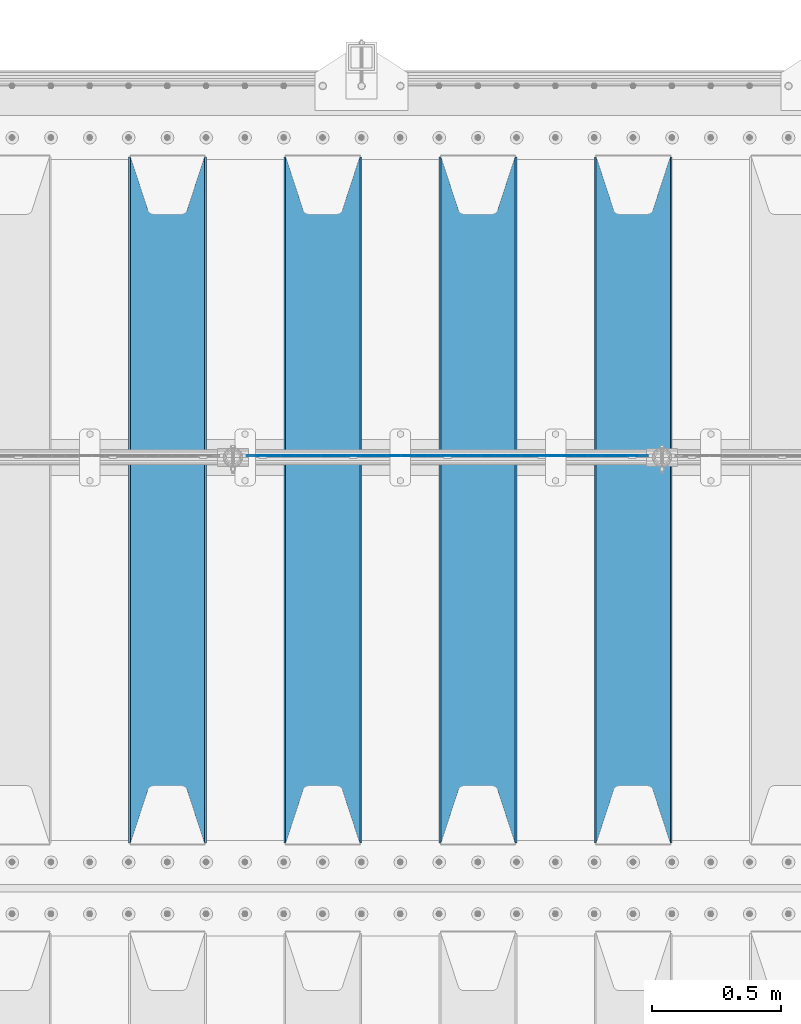
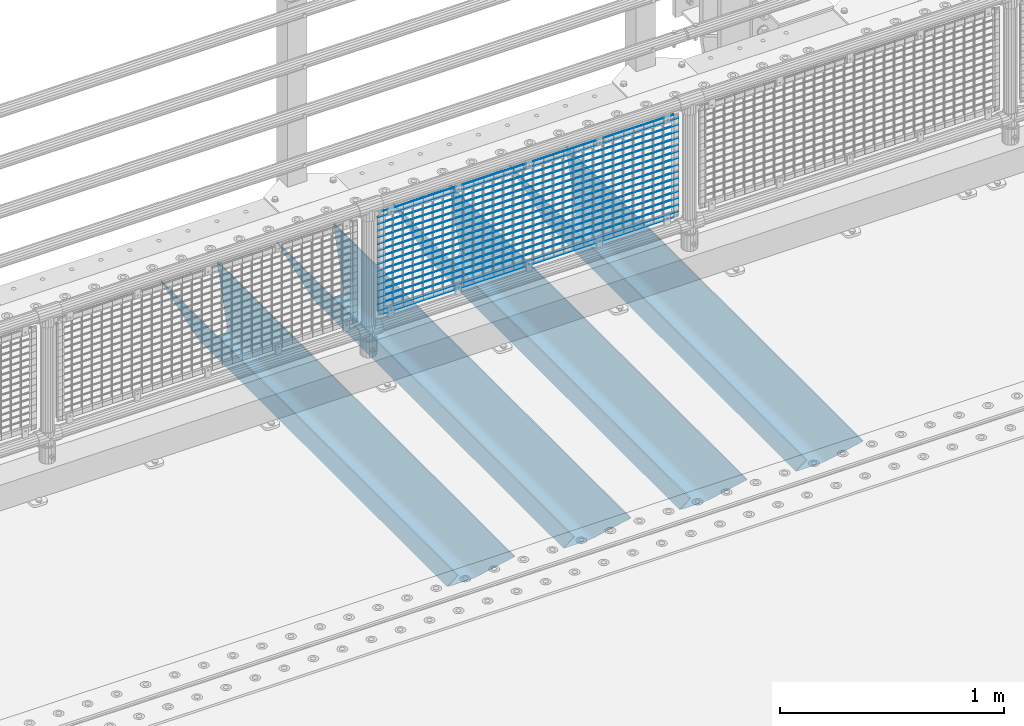
# One storey, part 121 of 240: 21 beams.
"""IFC2X3 building model written with IfcOpenShell, lengths in millimetres."""

from ifc_helpers import new_model, si_unit, frame, origin_with_axes, place, context, subcontext, project, spatial, faceted_brep, material, type_object, element, save


model = new_model("IFC2X3")

# Units and contexts
model_context = context("Model", 3, precision=1e-05, world=origin_with_axes())
body_context = subcontext(model_context, "Body", "Model", "MODEL_VIEW")
ifc_project = project(units=[si_unit("LENGTHUNIT", "METRE", prefix="MILLI"), si_unit("AREAUNIT", "SQUARE_METRE"), si_unit("VOLUMEUNIT", "CUBIC_METRE"), si_unit("MASSUNIT", "GRAM", prefix="KILO"), si_unit("TIMEUNIT", "SECOND"), si_unit("PLANEANGLEUNIT", "RADIAN"), si_unit("SOLIDANGLEUNIT", "STERADIAN"), si_unit("THERMODYNAMICTEMPERATUREUNIT", "DEGREE_CELSIUS"), si_unit("LUMINOUSINTENSITYUNIT", "LUMEN")], contexts=[model_context])

# Site, building, storey
site_placement = place(None, origin_with_axes())
site = spatial("IfcSite", under=ifc_project, at=site_placement, CompositionType="ELEMENT")
building_placement = place(site_placement, origin_with_axes())
building = spatial("IfcBuilding", under=site, at=building_placement, Name="Standard", CompositionType="ELEMENT")
storey_placement = place(building_placement, origin_with_axes())
storey = spatial("IfcBuildingStorey", under=building, at=storey_placement, Name="Undefined", CompositionType="ELEMENT", Elevation=0.0)

# Beams
ifc_material_1 = material(Name="STEEL/S355N")
beam_type_1 = type_object("IfcBeamType", PredefinedType="NOTDEFINED")
beam_1_placement = place(storey_placement, frame((51250.0, 33175.0, -115.0), z_axis=(0.0, 0.0, 1.0), x_axis=(0.0, 1.0, 0.0)))
element("IfcBeam", 1, at=beam_1_placement, inside=storey, type_object=beam_type_1, material=ifc_material_1, context=body_context, shape_type="Brep", body=[
    faceted_brep([(0.0, 150.0, 115.0), (0.0, 143.690000000002, 115.0), (2650.00000000297, 143.690000000002, 115.0), (2650.00000000297, 150.0, 115.0), (2650.00000000297, 142.059565218406, 110.000000003094), (2650.00000000297, 148.369565218403, 110.000000003094), (2441.90079219209, -80.1103600731149, -98.0992078077845), (2437.7588105432, -77.5672621345584, -102.241189456673), (2434.06523489747, -74.4080125315522, -105.934765102404), (2430.9108609509, -70.7102721255724, -109.089139048974), (2428.37322971128, -66.5649389910031, -111.626770288588), (2426.51472138055, -62.0739139532889, -113.485278619323), (2425.38102192092, -57.3475956567636, -114.618978078955), (2424.99999999987, -52.5021667386536, -115.0), (2424.99999999987, 52.5021667386536, -115.0), (2425.38102192092, 57.3475956567636, -114.618978078955), (2426.51472138055, 62.0739139532889, -113.485278619323), (2428.37322971128, 66.5649389910031, -111.626770288588), (2430.9108609509, 70.7102721255724, -109.089139048974), (2434.06523489747, 74.4080125315522, -105.934765102404), (2437.7588105432, 77.5672621345584, -102.241189456673), (2441.90079219209, 80.1103600731149, -98.0992078077846), (2446.38936140512, 81.9747917625791, -93.6106385947584), (2448.2494850041, 76.2713538057287, -91.7505149957729), (2444.62967112263, 74.76777986261, -95.3703288772456), (2441.28936334127, 72.7168944282894, -98.710636658607), (2438.31067330439, 70.1691124903809, -101.689326695487), (2435.76682334748, 67.1870637758839, -104.233176652398), (2433.72034654134, 63.8440531834931, -106.279653458539), (2432.22154950042, 60.2222587982324, -107.778450499454), (2431.30727574265, 56.4107117849126, -108.692724257221), (2430.99999999987, 52.5031078186876, -109.0), (2430.99999999987, -52.5031078186876, -109.0), (2431.30727574265, -56.4107117849126, -108.692724257221), (2432.22154950042, -60.2222587982324, -107.778450499454), (2433.72034654134, -63.8440531834931, -106.279653458539), (2435.76682334748, -67.1870637758839, -104.233176652398), (2438.31067330439, -70.1691124903809, -101.689326695487), (2441.28936334127, -72.7168944282894, -98.7106366586071), (2444.62967112263, -74.76777986261, -95.3703288772457), (2448.2494850041, -76.2713538057287, -91.7505149957729), (2650.00000000297, -142.059565218406, 110.000000003094), (2650.00000000297, -148.369565218403, 110.000000003094), (2446.38936140512, -81.9747917625791, -93.6106385947584), (2650.00000000297, -143.690000000002, 115.0), (2650.00000000297, -150.0, 115.0), (0.0, -143.690000000002, 115.0), (0.0, -150.0, 115.0), (0.0, -148.369565218258, 110.000000002667), (203.610638597427, -81.9747917625791, -93.6106385947584), (208.09920781045, -80.1103600731149, -98.0992078077845), (212.241189459342, -77.5672621345584, -102.241189456673), (215.93476510507, -74.4080125315522, -105.934765102404), (219.089139051641, -70.7102721255724, -109.089139048974), (221.626770291256, -66.5649389910031, -111.626770288588), (223.485278621989, -62.0739139532889, -113.485278619323), (224.618978081624, -57.3475956567636, -114.618978078955), (225.000000002663, -52.5021667386536, -115.0), (225.000000002663, 52.5021667386536, -115.0), (224.618978081624, 57.3475956567636, -114.618978078955), (223.485278621989, 62.0739139532889, -113.485278619323), (221.626770291256, 66.5649389910031, -111.626770288588), (219.089139051641, 70.7102721255724, -109.089139048974), (215.93476510507, 74.4080125315522, -105.934765102404), (212.241189459342, 77.5672621345584, -102.241189456673), (208.09920781045, 80.1103600731149, -98.0992078077846), (203.610638597427, 81.9747917625791, -93.6106385947584), (0.0, 148.369565218258, 110.000000002667), (0.0, 142.05956521826, 110.000000002667), (201.750514998439, 76.2713538057287, -91.7505149957729), (205.370328879908, 74.76777986261, -95.3703288772456), (208.710636661275, 72.7168944282894, -98.710636658607), (211.689326698153, 70.1691124903809, -101.689326695487), (214.233176655063, 67.1870637758839, -104.233176652398), (216.279653461206, 63.8440531834931, -106.279653458539), (217.778450502123, 60.2222587982324, -107.778450499454), (218.692724259887, 56.4107117849126, -108.692724257221), (219.000000002667, 52.5031078186876, -109.0), (219.000000002667, -52.5031078186876, -109.0), (218.692724259887, -56.4107117849126, -108.692724257221), (217.778450502123, -60.2222587982324, -107.778450499454), (216.279653461206, -63.8440531834931, -106.279653458539), (214.233176655063, -67.1870637758839, -104.233176652398), (211.689326698153, -70.1691124903809, -101.689326695487), (208.710636661275, -72.7168944282894, -98.7106366586071), (205.370328879915, -74.76777986261, -95.3703288772457), (201.750514998439, -76.2713538057287, -91.7505149957729), (0.0, -142.05956521826, 110.000000002667)], [[[0, 1, 2, 3]], [[3, 2, 4, 5]], [[6, 7, 8, 9, 10, 11, 12, 13, 14, 15, 16, 17, 18, 19, 20, 21, 22, 5, 4, 23, 24, 25, 26, 27, 28, 29, 30, 31, 32, 33, 34, 35, 36, 37, 38, 39, 40, 41, 42, 43]], [[44, 45, 42, 41]], [[46, 47, 45, 44]], [[43, 42, 45, 47, 48, 49]], [[6, 43, 49, 50]], [[7, 6, 50, 51]], [[8, 7, 51, 52]], [[9, 8, 52, 53]], [[10, 9, 53, 54]], [[11, 10, 54, 55]], [[12, 11, 55, 56]], [[13, 12, 56, 57]], [[14, 13, 57, 58]], [[15, 14, 58, 59]], [[16, 15, 59, 60]], [[17, 16, 60, 61]], [[18, 17, 61, 62]], [[19, 18, 62, 63]], [[20, 19, 63, 64]], [[21, 20, 64, 65]], [[22, 21, 65, 66]], [[0, 3, 5, 22, 66, 67]], [[1, 0, 67, 68]], [[23, 4, 2, 1, 68, 69]], [[24, 23, 69, 70]], [[25, 24, 70, 71]], [[26, 25, 71, 72]], [[27, 26, 72, 73]], [[28, 27, 73, 74]], [[29, 28, 74, 75]], [[30, 29, 75, 76]], [[31, 30, 76, 77]], [[32, 31, 77, 78]], [[33, 32, 78, 79]], [[34, 33, 79, 80]], [[35, 34, 80, 81]], [[36, 35, 81, 82]], [[37, 36, 82, 83]], [[38, 37, 83, 84]], [[39, 38, 84, 85]], [[40, 39, 85, 86]], [[46, 44, 41, 40, 86, 87]], [[47, 46, 87, 48]], [[86, 85, 84, 83, 82, 81, 80, 79, 78, 77, 76, 75, 74, 73, 72, 71, 70, 69, 68, 67, 66, 65, 64, 63, 62, 61, 60, 59, 58, 57, 56, 55, 54, 53, 52, 51, 50, 49, 48, 87]]]),
])
beam_2_placement = place(storey_placement, frame((50650.0, 33175.0, -115.0), z_axis=(0.0, 0.0, 1.0), x_axis=(0.0, 1.0, 0.0)))
element("IfcBeam", 2, at=beam_2_placement, inside=storey, type_object=beam_type_1, material=ifc_material_1, context=body_context, shape_type="Brep", body=[
    faceted_brep([(0.0, 150.0, 115.0), (0.0, 143.690000000002, 115.0), (2650.00000000297, 143.690000000002, 115.0), (2650.00000000297, 150.0, 115.0), (2650.00000000297, 142.059565218406, 110.000000003094), (2650.00000000297, 148.369565218403, 110.000000003094), (2441.90079219209, -80.1103600731149, -98.0992078077845), (2437.7588105432, -77.5672621345584, -102.241189456673), (2434.06523489747, -74.4080125315522, -105.934765102404), (2430.9108609509, -70.7102721255724, -109.089139048974), (2428.37322971128, -66.5649389910031, -111.626770288588), (2426.51472138055, -62.0739139532889, -113.485278619323), (2425.38102192092, -57.3475956567636, -114.618978078955), (2424.99999999987, -52.5021667386536, -115.0), (2424.99999999987, 52.5021667386536, -115.0), (2425.38102192092, 57.3475956567636, -114.618978078955), (2426.51472138055, 62.0739139532889, -113.485278619323), (2428.37322971128, 66.5649389910031, -111.626770288588), (2430.9108609509, 70.7102721255724, -109.089139048974), (2434.06523489747, 74.4080125315522, -105.934765102404), (2437.7588105432, 77.5672621345584, -102.241189456673), (2441.90079219209, 80.1103600731149, -98.0992078077846), (2446.38936140512, 81.9747917625791, -93.6106385947584), (2448.2494850041, 76.2713538057287, -91.7505149957729), (2444.62967112263, 74.76777986261, -95.3703288772456), (2441.28936334127, 72.7168944282894, -98.710636658607), (2438.31067330439, 70.1691124903809, -101.689326695487), (2435.76682334748, 67.1870637758839, -104.233176652398), (2433.72034654134, 63.8440531834931, -106.279653458539), (2432.22154950042, 60.2222587982324, -107.778450499454), (2431.30727574265, 56.4107117849126, -108.692724257221), (2430.99999999987, 52.5031078186876, -109.0), (2430.99999999987, -52.5031078186876, -109.0), (2431.30727574265, -56.4107117849126, -108.692724257221), (2432.22154950042, -60.2222587982324, -107.778450499454), (2433.72034654134, -63.8440531834931, -106.279653458539), (2435.76682334748, -67.1870637758839, -104.233176652398), (2438.31067330439, -70.1691124903809, -101.689326695487), (2441.28936334127, -72.7168944282894, -98.7106366586071), (2444.62967112263, -74.76777986261, -95.3703288772457), (2448.2494850041, -76.2713538057287, -91.7505149957729), (2650.00000000297, -142.059565218406, 110.000000003094), (2650.00000000297, -148.369565218403, 110.000000003094), (2446.38936140512, -81.9747917625791, -93.6106385947584), (2650.00000000297, -143.690000000002, 115.0), (2650.00000000297, -150.0, 115.0), (0.0, -143.690000000002, 115.0), (0.0, -150.0, 115.0), (0.0, -148.369565218258, 110.000000002667), (203.610638597427, -81.9747917625791, -93.6106385947584), (208.09920781045, -80.1103600731149, -98.0992078077845), (212.241189459342, -77.5672621345584, -102.241189456673), (215.93476510507, -74.4080125315522, -105.934765102404), (219.089139051641, -70.7102721255724, -109.089139048974), (221.626770291256, -66.5649389910031, -111.626770288588), (223.485278621989, -62.0739139532889, -113.485278619323), (224.618978081624, -57.3475956567636, -114.618978078955), (225.000000002663, -52.5021667386536, -115.0), (225.000000002663, 52.5021667386536, -115.0), (224.618978081624, 57.3475956567636, -114.618978078955), (223.485278621989, 62.0739139532889, -113.485278619323), (221.626770291256, 66.5649389910031, -111.626770288588), (219.089139051641, 70.7102721255724, -109.089139048974), (215.93476510507, 74.4080125315522, -105.934765102404), (212.241189459342, 77.5672621345584, -102.241189456673), (208.09920781045, 80.1103600731149, -98.0992078077846), (203.610638597427, 81.9747917625791, -93.6106385947584), (0.0, 148.369565218258, 110.000000002667), (0.0, 142.05956521826, 110.000000002667), (201.750514998439, 76.2713538057287, -91.7505149957729), (205.370328879908, 74.76777986261, -95.3703288772456), (208.710636661275, 72.7168944282894, -98.710636658607), (211.689326698153, 70.1691124903809, -101.689326695487), (214.233176655063, 67.1870637758839, -104.233176652398), (216.279653461206, 63.8440531834931, -106.279653458539), (217.778450502123, 60.2222587982324, -107.778450499454), (218.692724259887, 56.4107117849126, -108.692724257221), (219.000000002667, 52.5031078186876, -109.0), (219.000000002667, -52.5031078186876, -109.0), (218.692724259887, -56.4107117849126, -108.692724257221), (217.778450502123, -60.2222587982324, -107.778450499454), (216.279653461206, -63.8440531834931, -106.279653458539), (214.233176655063, -67.1870637758839, -104.233176652398), (211.689326698153, -70.1691124903809, -101.689326695487), (208.710636661275, -72.7168944282894, -98.7106366586071), (205.370328879915, -74.76777986261, -95.3703288772457), (201.750514998439, -76.2713538057287, -91.7505149957729), (0.0, -142.05956521826, 110.000000002667)], [[[0, 1, 2, 3]], [[3, 2, 4, 5]], [[6, 7, 8, 9, 10, 11, 12, 13, 14, 15, 16, 17, 18, 19, 20, 21, 22, 5, 4, 23, 24, 25, 26, 27, 28, 29, 30, 31, 32, 33, 34, 35, 36, 37, 38, 39, 40, 41, 42, 43]], [[44, 45, 42, 41]], [[46, 47, 45, 44]], [[43, 42, 45, 47, 48, 49]], [[6, 43, 49, 50]], [[7, 6, 50, 51]], [[8, 7, 51, 52]], [[9, 8, 52, 53]], [[10, 9, 53, 54]], [[11, 10, 54, 55]], [[12, 11, 55, 56]], [[13, 12, 56, 57]], [[14, 13, 57, 58]], [[15, 14, 58, 59]], [[16, 15, 59, 60]], [[17, 16, 60, 61]], [[18, 17, 61, 62]], [[19, 18, 62, 63]], [[20, 19, 63, 64]], [[21, 20, 64, 65]], [[22, 21, 65, 66]], [[0, 3, 5, 22, 66, 67]], [[1, 0, 67, 68]], [[23, 4, 2, 1, 68, 69]], [[24, 23, 69, 70]], [[25, 24, 70, 71]], [[26, 25, 71, 72]], [[27, 26, 72, 73]], [[28, 27, 73, 74]], [[29, 28, 74, 75]], [[30, 29, 75, 76]], [[31, 30, 76, 77]], [[32, 31, 77, 78]], [[33, 32, 78, 79]], [[34, 33, 79, 80]], [[35, 34, 80, 81]], [[36, 35, 81, 82]], [[37, 36, 82, 83]], [[38, 37, 83, 84]], [[39, 38, 84, 85]], [[40, 39, 85, 86]], [[46, 44, 41, 40, 86, 87]], [[47, 46, 87, 48]], [[86, 85, 84, 83, 82, 81, 80, 79, 78, 77, 76, 75, 74, 73, 72, 71, 70, 69, 68, 67, 66, 65, 64, 63, 62, 61, 60, 59, 58, 57, 56, 55, 54, 53, 52, 51, 50, 49, 48, 87]]]),
])
beam_3_placement = place(storey_placement, frame((50050.0, 33175.0, -115.0), z_axis=(0.0, 0.0, 1.0), x_axis=(0.0, 1.0, 0.0)))
element("IfcBeam", 3, at=beam_3_placement, inside=storey, type_object=beam_type_1, material=ifc_material_1, context=body_context, shape_type="Brep", body=[
    faceted_brep([(0.0, 150.0, 115.0), (0.0, 143.690000000002, 115.0), (2650.00000000297, 143.690000000002, 115.0), (2650.00000000297, 150.0, 115.0), (2650.00000000297, 142.059565218406, 110.000000003094), (2650.00000000297, 148.369565218403, 110.000000003094), (2441.90079219209, -80.1103600731149, -98.0992078077845), (2437.7588105432, -77.5672621345584, -102.241189456673), (2434.06523489747, -74.4080125315522, -105.934765102404), (2430.9108609509, -70.7102721255724, -109.089139048974), (2428.37322971128, -66.5649389910031, -111.626770288588), (2426.51472138055, -62.0739139532889, -113.485278619323), (2425.38102192092, -57.3475956567636, -114.618978078955), (2424.99999999987, -52.5021667386536, -115.0), (2424.99999999987, 52.5021667386536, -115.0), (2425.38102192092, 57.3475956567636, -114.618978078955), (2426.51472138055, 62.0739139532889, -113.485278619323), (2428.37322971128, 66.5649389910031, -111.626770288588), (2430.9108609509, 70.7102721255724, -109.089139048974), (2434.06523489747, 74.4080125315522, -105.934765102404), (2437.7588105432, 77.5672621345584, -102.241189456673), (2441.90079219209, 80.1103600731149, -98.0992078077846), (2446.38936140512, 81.9747917625791, -93.6106385947584), (2448.2494850041, 76.2713538057287, -91.7505149957729), (2444.62967112263, 74.76777986261, -95.3703288772456), (2441.28936334127, 72.7168944282894, -98.710636658607), (2438.31067330439, 70.1691124903809, -101.689326695487), (2435.76682334748, 67.1870637758839, -104.233176652398), (2433.72034654134, 63.8440531834931, -106.279653458539), (2432.22154950042, 60.2222587982324, -107.778450499454), (2431.30727574265, 56.4107117849126, -108.692724257221), (2430.99999999987, 52.5031078186876, -109.0), (2430.99999999987, -52.5031078186876, -109.0), (2431.30727574265, -56.4107117849126, -108.692724257221), (2432.22154950042, -60.2222587982324, -107.778450499454), (2433.72034654134, -63.8440531834931, -106.279653458539), (2435.76682334748, -67.1870637758839, -104.233176652398), (2438.31067330439, -70.1691124903809, -101.689326695487), (2441.28936334127, -72.7168944282894, -98.7106366586071), (2444.62967112263, -74.76777986261, -95.3703288772457), (2448.2494850041, -76.2713538057287, -91.7505149957729), (2650.00000000297, -142.059565218406, 110.000000003094), (2650.00000000297, -148.369565218403, 110.000000003094), (2446.38936140512, -81.9747917625791, -93.6106385947584), (2650.00000000297, -143.690000000002, 115.0), (2650.00000000297, -150.0, 115.0), (0.0, -143.690000000002, 115.0), (0.0, -150.0, 115.0), (0.0, -148.369565218258, 110.000000002667), (203.610638597427, -81.9747917625791, -93.6106385947584), (208.09920781045, -80.1103600731149, -98.0992078077845), (212.241189459342, -77.5672621345584, -102.241189456673), (215.93476510507, -74.4080125315522, -105.934765102404), (219.089139051641, -70.7102721255724, -109.089139048974), (221.626770291256, -66.5649389910031, -111.626770288588), (223.485278621989, -62.0739139532889, -113.485278619323), (224.618978081624, -57.3475956567636, -114.618978078955), (225.000000002663, -52.5021667386536, -115.0), (225.000000002663, 52.5021667386536, -115.0), (224.618978081624, 57.3475956567636, -114.618978078955), (223.485278621989, 62.0739139532889, -113.485278619323), (221.626770291256, 66.5649389910031, -111.626770288588), (219.089139051641, 70.7102721255724, -109.089139048974), (215.93476510507, 74.4080125315522, -105.934765102404), (212.241189459342, 77.5672621345584, -102.241189456673), (208.09920781045, 80.1103600731149, -98.0992078077846), (203.610638597427, 81.9747917625791, -93.6106385947584), (0.0, 148.369565218258, 110.000000002667), (0.0, 142.05956521826, 110.000000002667), (201.750514998439, 76.2713538057287, -91.7505149957729), (205.370328879908, 74.76777986261, -95.3703288772456), (208.710636661275, 72.7168944282894, -98.710636658607), (211.689326698153, 70.1691124903809, -101.689326695487), (214.233176655063, 67.1870637758839, -104.233176652398), (216.279653461206, 63.8440531834931, -106.279653458539), (217.778450502123, 60.2222587982324, -107.778450499454), (218.692724259887, 56.4107117849126, -108.692724257221), (219.000000002667, 52.5031078186876, -109.0), (219.000000002667, -52.5031078186876, -109.0), (218.692724259887, -56.4107117849126, -108.692724257221), (217.778450502123, -60.2222587982324, -107.778450499454), (216.279653461206, -63.8440531834931, -106.279653458539), (214.233176655063, -67.1870637758839, -104.233176652398), (211.689326698153, -70.1691124903809, -101.689326695487), (208.710636661275, -72.7168944282894, -98.7106366586071), (205.370328879915, -74.76777986261, -95.3703288772457), (201.750514998439, -76.2713538057287, -91.7505149957729), (0.0, -142.05956521826, 110.000000002667)], [[[0, 1, 2, 3]], [[3, 2, 4, 5]], [[6, 7, 8, 9, 10, 11, 12, 13, 14, 15, 16, 17, 18, 19, 20, 21, 22, 5, 4, 23, 24, 25, 26, 27, 28, 29, 30, 31, 32, 33, 34, 35, 36, 37, 38, 39, 40, 41, 42, 43]], [[44, 45, 42, 41]], [[46, 47, 45, 44]], [[43, 42, 45, 47, 48, 49]], [[6, 43, 49, 50]], [[7, 6, 50, 51]], [[8, 7, 51, 52]], [[9, 8, 52, 53]], [[10, 9, 53, 54]], [[11, 10, 54, 55]], [[12, 11, 55, 56]], [[13, 12, 56, 57]], [[14, 13, 57, 58]], [[15, 14, 58, 59]], [[16, 15, 59, 60]], [[17, 16, 60, 61]], [[18, 17, 61, 62]], [[19, 18, 62, 63]], [[20, 19, 63, 64]], [[21, 20, 64, 65]], [[22, 21, 65, 66]], [[0, 3, 5, 22, 66, 67]], [[1, 0, 67, 68]], [[23, 4, 2, 1, 68, 69]], [[24, 23, 69, 70]], [[25, 24, 70, 71]], [[26, 25, 71, 72]], [[27, 26, 72, 73]], [[28, 27, 73, 74]], [[29, 28, 74, 75]], [[30, 29, 75, 76]], [[31, 30, 76, 77]], [[32, 31, 77, 78]], [[33, 32, 78, 79]], [[34, 33, 79, 80]], [[35, 34, 80, 81]], [[36, 35, 81, 82]], [[37, 36, 82, 83]], [[38, 37, 83, 84]], [[39, 38, 84, 85]], [[40, 39, 85, 86]], [[46, 44, 41, 40, 86, 87]], [[47, 46, 87, 48]], [[86, 85, 84, 83, 82, 81, 80, 79, 78, 77, 76, 75, 74, 73, 72, 71, 70, 69, 68, 67, 66, 65, 64, 63, 62, 61, 60, 59, 58, 57, 56, 55, 54, 53, 52, 51, 50, 49, 48, 87]]]),
])
beam_4_placement = place(storey_placement, frame((49450.0, 33175.0, -115.0), z_axis=(0.0, 0.0, 1.0), x_axis=(0.0, 1.0, 0.0)))
element("IfcBeam", 4, at=beam_4_placement, inside=storey, type_object=beam_type_1, material=ifc_material_1, context=body_context, shape_type="Brep", body=[
    faceted_brep([(0.0, 150.0, 115.0), (0.0, 143.690000000002, 115.0), (2650.00000000297, 143.690000000002, 115.0), (2650.00000000297, 150.0, 115.0), (2650.00000000297, 142.059565218406, 110.000000003094), (2650.00000000297, 148.369565218403, 110.000000003094), (2441.90079219209, -80.1103600731149, -98.0992078077845), (2437.7588105432, -77.5672621345584, -102.241189456673), (2434.06523489747, -74.4080125315522, -105.934765102404), (2430.9108609509, -70.7102721255724, -109.089139048974), (2428.37322971128, -66.5649389910031, -111.626770288588), (2426.51472138055, -62.0739139532889, -113.485278619323), (2425.38102192092, -57.3475956567636, -114.618978078955), (2424.99999999987, -52.5021667386536, -115.0), (2424.99999999987, 52.5021667386536, -115.0), (2425.38102192092, 57.3475956567636, -114.618978078955), (2426.51472138055, 62.0739139532889, -113.485278619323), (2428.37322971128, 66.5649389910031, -111.626770288588), (2430.9108609509, 70.7102721255724, -109.089139048974), (2434.06523489747, 74.4080125315522, -105.934765102404), (2437.7588105432, 77.5672621345584, -102.241189456673), (2441.90079219209, 80.1103600731149, -98.0992078077846), (2446.38936140512, 81.9747917625791, -93.6106385947584), (2448.2494850041, 76.2713538057287, -91.7505149957729), (2444.62967112263, 74.76777986261, -95.3703288772456), (2441.28936334127, 72.7168944282894, -98.710636658607), (2438.31067330439, 70.1691124903809, -101.689326695487), (2435.76682334748, 67.1870637758839, -104.233176652398), (2433.72034654134, 63.8440531834931, -106.279653458539), (2432.22154950042, 60.2222587982324, -107.778450499454), (2431.30727574265, 56.4107117849126, -108.692724257221), (2430.99999999987, 52.5031078186876, -109.0), (2430.99999999987, -52.5031078186876, -109.0), (2431.30727574265, -56.4107117849126, -108.692724257221), (2432.22154950042, -60.2222587982324, -107.778450499454), (2433.72034654134, -63.8440531834931, -106.279653458539), (2435.76682334748, -67.1870637758839, -104.233176652398), (2438.31067330439, -70.1691124903809, -101.689326695487), (2441.28936334127, -72.7168944282894, -98.7106366586071), (2444.62967112263, -74.76777986261, -95.3703288772457), (2448.2494850041, -76.2713538057287, -91.7505149957729), (2650.00000000297, -142.059565218406, 110.000000003094), (2650.00000000297, -148.369565218403, 110.000000003094), (2446.38936140512, -81.9747917625791, -93.6106385947584), (2650.00000000297, -143.690000000002, 115.0), (2650.00000000297, -150.0, 115.0), (0.0, -143.690000000002, 115.0), (0.0, -150.0, 115.0), (0.0, -148.369565218258, 110.000000002667), (203.610638597427, -81.9747917625791, -93.6106385947584), (208.09920781045, -80.1103600731149, -98.0992078077845), (212.241189459342, -77.5672621345584, -102.241189456673), (215.93476510507, -74.4080125315522, -105.934765102404), (219.089139051641, -70.7102721255724, -109.089139048974), (221.626770291256, -66.5649389910031, -111.626770288588), (223.485278621989, -62.0739139532889, -113.485278619323), (224.618978081624, -57.3475956567636, -114.618978078955), (225.000000002663, -52.5021667386536, -115.0), (225.000000002663, 52.5021667386536, -115.0), (224.618978081624, 57.3475956567636, -114.618978078955), (223.485278621989, 62.0739139532889, -113.485278619323), (221.626770291256, 66.5649389910031, -111.626770288588), (219.089139051641, 70.7102721255724, -109.089139048974), (215.93476510507, 74.4080125315522, -105.934765102404), (212.241189459342, 77.5672621345584, -102.241189456673), (208.09920781045, 80.1103600731149, -98.0992078077846), (203.610638597427, 81.9747917625791, -93.6106385947584), (0.0, 148.369565218258, 110.000000002667), (0.0, 142.05956521826, 110.000000002667), (201.750514998439, 76.2713538057287, -91.7505149957729), (205.370328879908, 74.76777986261, -95.3703288772456), (208.710636661275, 72.7168944282894, -98.710636658607), (211.689326698153, 70.1691124903809, -101.689326695487), (214.233176655063, 67.1870637758839, -104.233176652398), (216.279653461206, 63.8440531834931, -106.279653458539), (217.778450502123, 60.2222587982324, -107.778450499454), (218.692724259887, 56.4107117849126, -108.692724257221), (219.000000002667, 52.5031078186876, -109.0), (219.000000002667, -52.5031078186876, -109.0), (218.692724259887, -56.4107117849126, -108.692724257221), (217.778450502123, -60.2222587982324, -107.778450499454), (216.279653461206, -63.8440531834931, -106.279653458539), (214.233176655063, -67.1870637758839, -104.233176652398), (211.689326698153, -70.1691124903809, -101.689326695487), (208.710636661275, -72.7168944282894, -98.7106366586071), (205.370328879915, -74.76777986261, -95.3703288772457), (201.750514998439, -76.2713538057287, -91.7505149957729), (0.0, -142.05956521826, 110.000000002667)], [[[0, 1, 2, 3]], [[3, 2, 4, 5]], [[6, 7, 8, 9, 10, 11, 12, 13, 14, 15, 16, 17, 18, 19, 20, 21, 22, 5, 4, 23, 24, 25, 26, 27, 28, 29, 30, 31, 32, 33, 34, 35, 36, 37, 38, 39, 40, 41, 42, 43]], [[44, 45, 42, 41]], [[46, 47, 45, 44]], [[43, 42, 45, 47, 48, 49]], [[6, 43, 49, 50]], [[7, 6, 50, 51]], [[8, 7, 51, 52]], [[9, 8, 52, 53]], [[10, 9, 53, 54]], [[11, 10, 54, 55]], [[12, 11, 55, 56]], [[13, 12, 56, 57]], [[14, 13, 57, 58]], [[15, 14, 58, 59]], [[16, 15, 59, 60]], [[17, 16, 60, 61]], [[18, 17, 61, 62]], [[19, 18, 62, 63]], [[20, 19, 63, 64]], [[21, 20, 64, 65]], [[22, 21, 65, 66]], [[0, 3, 5, 22, 66, 67]], [[1, 0, 67, 68]], [[23, 4, 2, 1, 68, 69]], [[24, 23, 69, 70]], [[25, 24, 70, 71]], [[26, 25, 71, 72]], [[27, 26, 72, 73]], [[28, 27, 73, 74]], [[29, 28, 74, 75]], [[30, 29, 75, 76]], [[31, 30, 76, 77]], [[32, 31, 77, 78]], [[33, 32, 78, 79]], [[34, 33, 79, 80]], [[35, 34, 80, 81]], [[36, 35, 81, 82]], [[37, 36, 82, 83]], [[38, 37, 83, 84]], [[39, 38, 84, 85]], [[40, 39, 85, 86]], [[46, 44, 41, 40, 86, 87]], [[47, 46, 87, 48]], [[86, 85, 84, 83, 82, 81, 80, 79, 78, 77, 76, 75, 74, 73, 72, 71, 70, 69, 68, 67, 66, 65, 64, 63, 62, 61, 60, 59, 58, 57, 56, 55, 54, 53, 52, 51, 50, 49, 48, 87]]]),
])
ifc_material_2 = material(Name="Misc_Undefined")
beam_type_2 = type_object("IfcBeamType", Name="D3", PredefinedType="NOTDEFINED")
for number, where, z_axis, x_axis in (
    (5, (49758.0, 34670.5, 851.597), (0.0, 0.0, 1.0), (1.0, 0.0, 0.0)),
    (6, (49758.0, 34670.5, 669.452000000001), (0.0, 0.0, 1.0), (1.0, 0.0, 0.0)),
    (7, (49758.0, 34670.5, 523.736000000001), (0.0, 0.0, 1.0), (1.0, 0.0, 0.0)),
    (8, (49758.0, 34670.5, 487.307000000001), (0.0, 0.0, 1.0), (1.0, 0.0, 0.0)),
    (9, (49758.0, 34670.5, 705.881000000001), (0.0, 0.0, 1.0), (1.0, 0.0, 0.0)),
    (10, (49758.0, 34670.5, 596.594000000001), (0.0, 0.0, 1.0), (1.0, 0.0, 0.0)),
    (11, (49758.0, 34670.5, 450.878000000001), (0.0, 0.0, 1.0), (1.0, 0.0, 0.0)),
    (12, (49758.0, 34670.5, 815.168000000001), (0.0, 0.0, 1.0), (1.0, 0.0, 0.0)),
    (13, (49758.0, 34670.5, 888.026000000001), (0.0, 0.0, 1.0), (1.0, 0.0, 0.0)),
    (14, (49758.0, 34670.5, 778.739000000001), (0.0, 0.0, 1.0), (1.0, 0.0, 0.0)),
    (15, (49758.0, 34670.5, 742.310000000001), (0.0, 0.0, 1.0), (1.0, 0.0, 0.0)),
    (16, (49758.0, 34670.5, 633.023000000001), (0.0, 0.0, 1.0), (1.0, 0.0, 0.0)),
    (17, (49758.0, 34670.5, 560.165000000001), (0.0, 0.0, 1.0), (1.0, 0.0, 0.0)),
    (18, (49758.0, 34670.5, 414.449000000001), (0.0, 0.0, 1.0), (1.0, 0.0, 0.0)),
):
    element("IfcBeam", number, at=place(storey_placement, frame(where, z_axis=z_axis, x_axis=x_axis)), inside=storey, type_object=beam_type_2, material=ifc_material_2, ObjectType="D3", context=body_context, shape_type="Brep", body=[
        faceted_brep([(-7.27595761418343e-12, -1.49999999999272, 0.0), (-7.27595761418343e-12, -0.749999999992724, -1.29903810567669), (1548.0, -0.75, -1.29903810567669), (1548.0, -1.5, 0.0), (0.0, 0.750000000007276, -1.29903810567669), (1548.0, 0.75, -1.29903810567669), (0.0, 1.50000000000728, 0.0), (1548.0, 1.5, 0.0), (0.0, 0.750000000007276, 1.29903810567669), (1548.0, 0.75, 1.29903810567669), (-7.27595761418343e-12, -0.749999999992724, 1.29903810567669), (1548.0, -0.75, 1.29903810567669)], [[[0, 1, 2, 3]], [[1, 4, 5, 2]], [[4, 6, 7, 5]], [[6, 8, 9, 7]], [[8, 10, 11, 9]], [[10, 0, 3, 11]], [[5, 7, 9, 11, 3, 2]], [[10, 8, 6, 4, 1, 0]]]),
    ])
beam_5_placement = place(storey_placement, frame((49783.0, 34670.5, 353.020000000001), z_axis=(0.0, 0.0, 1.0), x_axis=(1.0, 0.0, 0.0)))
element("IfcBeam", 19, at=beam_5_placement, inside=storey, type_object=beam_type_2, material=ifc_material_2, ObjectType="D3", context=body_context, shape_type="Brep", body=[
    faceted_brep([(-7.27595761418343e-12, -1.49999999999272, 0.0), (-7.27595761418343e-12, -0.749999999992724, -1.29903810567669), (1498.0, -0.75, -1.29903810567669), (1498.0, -1.5, 0.0), (0.0, 0.750000000007276, -1.29903810567669), (1498.0, 0.75, -1.29903810567663), (0.0, 1.50000000000728, 0.0), (1498.0, 1.5, 0.0), (0.0, 0.750000000007276, 1.29903810567669), (1498.0, 0.75, 1.29903810567669), (-7.27595761418343e-12, -0.749999999992724, 1.29903810567669), (1498.0, -0.75, 1.29903810567669)], [[[0, 1, 2, 3]], [[1, 4, 5, 2]], [[4, 6, 7, 5]], [[6, 8, 9, 7]], [[8, 10, 11, 9]], [[10, 0, 3, 11]], [[5, 7, 9, 11, 3, 2]], [[10, 8, 6, 4, 1, 0]]]),
])
beam_6_placement = place(storey_placement, frame((49758.0, 34670.5, 378.020000000001), z_axis=(0.0, 0.0, 1.0), x_axis=(1.0, 0.0, 0.0)))
element("IfcBeam", 20, at=beam_6_placement, inside=storey, type_object=beam_type_2, material=ifc_material_2, ObjectType="D3", context=body_context, shape_type="Brep", body=[
    faceted_brep([(-7.27595761418343e-12, -1.49999999999272, 0.0), (-7.27595761418343e-12, -0.749999999992724, -1.29903810567669), (1548.0, -0.75, -1.29903810567669), (1548.0, -1.5, 0.0), (0.0, 0.750000000007276, -1.29903810567669), (1548.0, 0.75, -1.29903810567669), (0.0, 1.50000000000728, 0.0), (1548.0, 1.5, 0.0), (0.0, 0.750000000007276, 1.29903810567669), (1548.0, 0.75, 1.29903810567669), (-7.27595761418343e-12, -0.749999999992724, 1.29903810567669), (1548.0, -0.75, 1.29903810567669)], [[[0, 1, 2, 3]], [[1, 4, 5, 2]], [[4, 6, 7, 5]], [[6, 8, 9, 7]], [[8, 10, 11, 9]], [[10, 0, 3, 11]], [[5, 7, 9, 11, 3, 2]], [[10, 8, 6, 4, 1, 0]]]),
])
beam_7_placement = place(storey_placement, frame((49783.0, 34670.5, 913.020000000001), z_axis=(0.0, 0.0, 1.0), x_axis=(1.0, 0.0, 0.0)))
element("IfcBeam", 21, at=beam_7_placement, inside=storey, type_object=beam_type_2, material=ifc_material_2, ObjectType="D3", context=body_context, shape_type="Brep", body=[
    faceted_brep([(-7.27595761418343e-12, -1.49999999999272, 0.0), (-7.27595761418343e-12, -0.749999999992724, -1.29903810567669), (1498.0, -0.75, -1.29903810567669), (1498.0, -1.5, 0.0), (0.0, 0.750000000007276, -1.29903810567669), (1498.0, 0.75, -1.29903810567663), (0.0, 1.50000000000728, 0.0), (1498.0, 1.5, 0.0), (0.0, 0.750000000007276, 1.29903810567669), (1498.0, 0.75, 1.29903810567669), (-7.27595761418343e-12, -0.749999999992724, 1.29903810567669), (1498.0, -0.75, 1.29903810567669)], [[[0, 1, 2, 3]], [[1, 4, 5, 2]], [[4, 6, 7, 5]], [[6, 8, 9, 7]], [[8, 10, 11, 9]], [[10, 0, 3, 11]], [[5, 7, 9, 11, 3, 2]], [[10, 8, 6, 4, 1, 0]]]),
])

save(model, "model.ifc")
